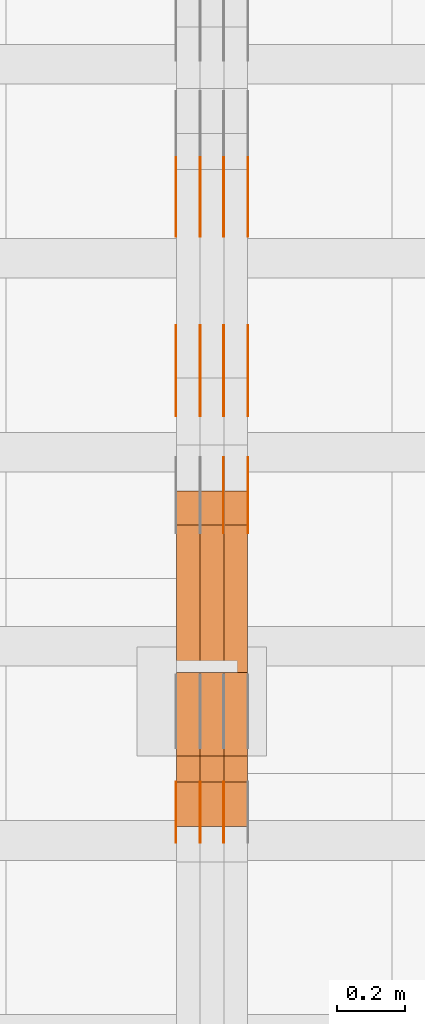
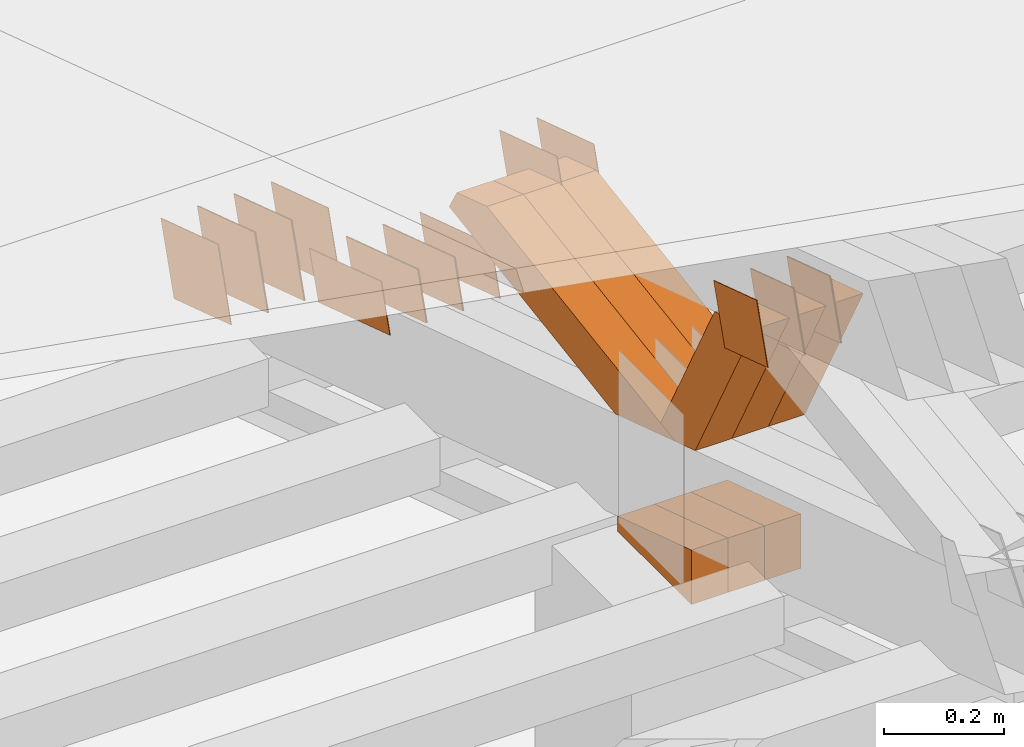
# One storey, part 89 of 385: 28 proxies.
"""IFC2X3 building model written with IfcOpenShell, lengths in millimetres."""

from ifc_helpers import new_model, entity, si_unit, converted_unit, derived_unit, direction, frame, origin, place, context, subcontext, project, spatial, polyline, outline, extrude, source, transform, mapped, material, type_object, type_shapes, element, save


model = new_model("IFC2X3")

# Units and contexts
model_context = context("Model", 3, precision=0.01, world=origin(), true_north=direction((6.12303176911189e-17, 1.0)))
body_context = subcontext(model_context, "Body", "Model", "MODEL_VIEW")
ifc_project = project(units=[si_unit("LENGTHUNIT", "METRE", prefix="MILLI"), si_unit("AREAUNIT", "SQUARE_METRE"), si_unit("VOLUMEUNIT", "CUBIC_METRE"), converted_unit("PLANEANGLEUNIT", "DEGREE", entity("IfcRatioMeasure", 0.0174532925199433), si_unit("PLANEANGLEUNIT", "RADIAN"), dimensions=[0, 0, 0, 0, 0, 0, 0]), si_unit("MASSUNIT", "GRAM", prefix="KILO"), derived_unit("MASSDENSITYUNIT", [(si_unit("MASSUNIT", "GRAM", prefix="KILO"), 1), (si_unit("LENGTHUNIT", "METRE"), -3)]), si_unit("TIMEUNIT", "SECOND"), si_unit("FREQUENCYUNIT", "HERTZ"), si_unit("THERMODYNAMICTEMPERATUREUNIT", "DEGREE_CELSIUS"), derived_unit("THERMALTRANSMITTANCEUNIT", [(si_unit("MASSUNIT", "GRAM", prefix="KILO"), 1), (si_unit("THERMODYNAMICTEMPERATUREUNIT", "KELVIN"), -1), (si_unit("TIMEUNIT", "SECOND"), -3)]), derived_unit("VOLUMETRICFLOWRATEUNIT", [(si_unit("LENGTHUNIT", "METRE"), 3), (si_unit("TIMEUNIT", "SECOND"), -1)]), si_unit("ELECTRICCURRENTUNIT", "AMPERE"), si_unit("ELECTRICVOLTAGEUNIT", "VOLT"), si_unit("POWERUNIT", "WATT"), si_unit("FORCEUNIT", "NEWTON", prefix="KILO"), si_unit("ILLUMINANCEUNIT", "LUX"), si_unit("LUMINOUSFLUXUNIT", "LUMEN"), si_unit("LUMINOUSINTENSITYUNIT", "CANDELA"), derived_unit("USERDEFINED", [(si_unit("MASSUNIT", "GRAM", prefix="KILO"), -1), (si_unit("LENGTHUNIT", "METRE"), -2), (si_unit("TIMEUNIT", "SECOND"), 3), (si_unit("LUMINOUSFLUXUNIT", "LUMEN"), 1)]), derived_unit("LINEARVELOCITYUNIT", [(si_unit("LENGTHUNIT", "METRE"), 1), (si_unit("TIMEUNIT", "SECOND"), -1)]), si_unit("PRESSUREUNIT", "PASCAL"), derived_unit("USERDEFINED", [(si_unit("LENGTHUNIT", "METRE"), -2), (si_unit("MASSUNIT", "GRAM", prefix="KILO"), 1), (si_unit("TIMEUNIT", "SECOND"), -2)])], contexts=[model_context])

# Site, building, storey
site_placement = place(None, origin())
site = spatial("IfcSite", under=ifc_project, at=site_placement, CompositionType="ELEMENT")
building_placement = place(site_placement, origin())
building = spatial("IfcBuilding", under=site, at=building_placement, CompositionType="ELEMENT")
storey_placement = place(building_placement, origin())
storey = spatial("IfcBuildingStorey", under=building, at=storey_placement, Name="Default", CompositionType="ELEMENT", Elevation=0.0)

# Proxies
ifc_material_1 = material(Name="IfcSurfaceStyle #101398")
building_element_proxy_type_1 = type_object("IfcBuildingElementProxyType", PredefinedType="NOTDEFINED", material=ifc_material_1)
shared_shape_1 = source(origin(), body_context, "Body", "SweptSolid", [
    extrude(outline(polyline([(-125.00031378339, -47.9999612158856), (125.000225258022, -47.9999612158856), (124.999811678525, 47.9999612158856), (-124.999723153156, 47.9999612158856), (-125.00031378339, -47.9999612158856)])), frame((125.000225258022, 48.0000091013474, 0.0), z_axis=(0.0, 0.0, 1.0), x_axis=(-1.0, 0.0, 0.0)), (0.0, 0.0, 1.0), 1.3),
])
type_shapes(building_element_proxy_type_1, [shared_shape_1])
proxy_1_placement = place(building_placement, frame((6386.29999999999, 18456.8597683375, 2657.46691321253), z_axis=(-1.0, 0.0, 0.0), x_axis=(0.0, -0.951056516295124, 0.309016994375039)))
element("IfcBuildingElementProxy", 1, at=proxy_1_placement, inside=storey, type_object=building_element_proxy_type_1, material=ifc_material_1, context=body_context, shape_type="MappedRepresentation", body=[
    mapped(shared_shape_1, transform((0.0, 0.0, 0.0), scale=1.0)),
])
ifc_material_2 = material(Name="IfcSurfaceStyle #101341")
building_element_proxy_type_2 = type_object("IfcBuildingElementProxyType", PredefinedType="NOTDEFINED", material=ifc_material_2)
shared_shape_2 = source(origin(), body_context, "Body", "SweptSolid", [
    extrude(outline(polyline([(-125.00031378339, -47.9999612158856), (125.000225258022, -47.9999612158856), (124.999811678525, 47.9999612158856), (-124.999723153156, 47.9999612158856), (-125.00031378339, -47.9999612158856)])), frame((125.000225258022, 48.0000091013474, 0.0), z_axis=(0.0, 0.0, 1.0), x_axis=(-1.0, 0.0, 0.0)), (0.0, 0.0, 1.0), 1.3),
])
type_shapes(building_element_proxy_type_2, [shared_shape_2])
proxy_2_placement = place(building_placement, frame((6315.0, 18456.8597683375, 2657.46691321253), z_axis=(-1.0, 0.0, 0.0), x_axis=(0.0, -0.951056516295124, 0.309016994375039)))
element("IfcBuildingElementProxy", 2, at=proxy_2_placement, inside=storey, type_object=building_element_proxy_type_2, material=ifc_material_2, context=body_context, shape_type="MappedRepresentation", body=[
    mapped(shared_shape_2, transform((0.0, 0.0, 0.0), scale=1.0)),
])
ifc_material_3 = material(Name="IfcSurfaceStyle #101284")
building_element_proxy_type_3 = type_object("IfcBuildingElementProxyType", PredefinedType="NOTDEFINED", material=ifc_material_3)
shared_shape_3 = source(origin(), body_context, "Body", "SweptSolid", [
    extrude(outline(polyline([(-125.00031378339, -47.9999612158856), (125.000225258022, -47.9999612158856), (124.999811678525, 47.9999612158856), (-124.999723153156, 47.9999612158856), (-125.00031378339, -47.9999612158856)])), frame((125.000225258022, 48.0000091013474, 0.0), z_axis=(0.0, 0.0, 1.0), x_axis=(-1.0, 0.0, 0.0)), (0.0, 0.0, 1.0), 1.3),
])
type_shapes(building_element_proxy_type_3, [shared_shape_3])
proxy_3_placement = place(building_placement, frame((6316.29999999999, 18456.8597683375, 2657.46691321253), z_axis=(-1.0, 0.0, 0.0), x_axis=(0.0, -0.951056516295124, 0.309016994375039)))
element("IfcBuildingElementProxy", 3, at=proxy_3_placement, inside=storey, type_object=building_element_proxy_type_3, material=ifc_material_3, context=body_context, shape_type="MappedRepresentation", body=[
    mapped(shared_shape_3, transform((0.0, 0.0, 0.0), scale=1.0)),
])
ifc_material_4 = material(Name="IfcSurfaceStyle #101227")
building_element_proxy_type_4 = type_object("IfcBuildingElementProxyType", PredefinedType="NOTDEFINED", material=ifc_material_4)
shared_shape_4 = source(origin(), body_context, "Body", "SweptSolid", [
    extrude(outline(polyline([(-125.00031378339, -47.9999612158856), (125.000225258022, -47.9999612158856), (124.999811678525, 47.9999612158856), (-124.999723153156, 47.9999612158856), (-125.00031378339, -47.9999612158856)])), frame((125.000225258022, 48.0000091013474, 0.0), z_axis=(0.0, 0.0, 1.0), x_axis=(-1.0, 0.0, 0.0)), (0.0, 0.0, 1.0), 1.29999999999998),
])
type_shapes(building_element_proxy_type_4, [shared_shape_4])
proxy_4_placement = place(building_placement, frame((6245.0, 18456.8597683375, 2657.46691321253), z_axis=(-1.0, 0.0, 0.0), x_axis=(0.0, -0.951056516295124, 0.309016994375039)))
element("IfcBuildingElementProxy", 4, at=proxy_4_placement, inside=storey, type_object=building_element_proxy_type_4, material=ifc_material_4, context=body_context, shape_type="MappedRepresentation", body=[
    mapped(shared_shape_4, transform((0.0, 0.0, 0.0), scale=1.0)),
])
ifc_material_5 = material(Name="IfcSurfaceStyle #101170")
building_element_proxy_type_5 = type_object("IfcBuildingElementProxyType", PredefinedType="NOTDEFINED", material=ifc_material_5)
shared_shape_5 = source(origin(), body_context, "Body", "SweptSolid", [
    extrude(outline(polyline([(-125.00031378339, -47.9999612158856), (125.000225258022, -47.9999612158856), (124.999811678525, 47.9999612158856), (-124.999723153156, 47.9999612158856), (-125.00031378339, -47.9999612158856)])), frame((125.000225258022, 48.0000091013474, 0.0), z_axis=(0.0, 0.0, 1.0), x_axis=(-1.0, 0.0, 0.0)), (0.0, 0.0, 1.0), 1.29999999999998),
])
type_shapes(building_element_proxy_type_5, [shared_shape_5])
proxy_5_placement = place(building_placement, frame((6246.29999999999, 18456.8597683375, 2657.46691321253), z_axis=(-1.0, 0.0, 0.0), x_axis=(0.0, -0.951056516295124, 0.309016994375039)))
element("IfcBuildingElementProxy", 5, at=proxy_5_placement, inside=storey, type_object=building_element_proxy_type_5, material=ifc_material_5, context=body_context, shape_type="MappedRepresentation", body=[
    mapped(shared_shape_5, transform((0.0, 0.0, 0.0), scale=1.0)),
])
ifc_material_6 = material(Name="IfcSurfaceStyle #101113")
building_element_proxy_type_6 = type_object("IfcBuildingElementProxyType", PredefinedType="NOTDEFINED", material=ifc_material_6)
shared_shape_6 = source(origin(), body_context, "Body", "SweptSolid", [
    extrude(outline(polyline([(-125.00031378339, -47.9999612158856), (125.000225258022, -47.9999612158856), (124.999811678525, 47.9999612158856), (-124.999723153156, 47.9999612158856), (-125.00031378339, -47.9999612158856)])), frame((125.000225258022, 48.0000091013474, 0.0), z_axis=(0.0, 0.0, 1.0), x_axis=(-1.0, 0.0, 0.0)), (0.0, 0.0, 1.0), 1.29999999999998),
])
type_shapes(building_element_proxy_type_6, [shared_shape_6])
proxy_6_placement = place(building_placement, frame((6175.0, 18456.8597683375, 2657.46691321253), z_axis=(-1.0, 0.0, 0.0), x_axis=(0.0, -0.951056516295124, 0.309016994375039)))
element("IfcBuildingElementProxy", 6, at=proxy_6_placement, inside=storey, type_object=building_element_proxy_type_6, material=ifc_material_6, context=body_context, shape_type="MappedRepresentation", body=[
    mapped(shared_shape_6, transform((0.0, 0.0, 0.0), scale=1.0)),
])
ifc_material_7 = material(Name="IfcSurfaceStyle #99688")
building_element_proxy_type_7 = type_object("IfcBuildingElementProxyType", PredefinedType="NOTDEFINED", material=ifc_material_7)
shared_shape_7 = source(origin(), body_context, "Body", "SweptSolid", [
    extrude(outline(polyline([(-99.999796294464, -72.0000050220467), (99.9998768370438, -72.0000050220467), (100.000260677528, 72.0000050220467), (-100.000341220108, 72.0000050220467), (-99.999796294464, -72.0000050220467)])), frame((100.000260677528, 72.0000050220467, 0.0), z_axis=(0.0, 0.0, 1.0), x_axis=(-1.0, 0.0, 0.0)), (0.0, 0.0, 1.0), 1.3),
])
type_shapes(building_element_proxy_type_7, [shared_shape_7])
proxy_7_placement = place(building_placement, frame((6386.29999999999, 18936.3876569477, 2373.90613192527), z_axis=(-1.0, 0.0, 0.0), x_axis=(0.0, -0.951056516295124, 0.309016994375039)))
element("IfcBuildingElementProxy", 7, at=proxy_7_placement, inside=storey, type_object=building_element_proxy_type_7, material=ifc_material_7, context=body_context, shape_type="MappedRepresentation", body=[
    mapped(shared_shape_7, transform((0.0, 0.0, 0.0), scale=1.0)),
])
ifc_material_8 = material(Name="IfcSurfaceStyle #99631")
building_element_proxy_type_8 = type_object("IfcBuildingElementProxyType", PredefinedType="NOTDEFINED", material=ifc_material_8)
shared_shape_8 = source(origin(), body_context, "Body", "SweptSolid", [
    extrude(outline(polyline([(-99.999796294464, -72.0000050220467), (99.9998768370438, -72.0000050220467), (100.000260677528, 72.0000050220467), (-100.000341220108, 72.0000050220467), (-99.999796294464, -72.0000050220467)])), frame((100.000260677528, 72.0000050220467, 0.0), z_axis=(0.0, 0.0, 1.0), x_axis=(-1.0, 0.0, 0.0)), (0.0, 0.0, 1.0), 1.3),
])
type_shapes(building_element_proxy_type_8, [shared_shape_8])
proxy_8_placement = place(building_placement, frame((6315.0, 18936.3876569477, 2373.90613192527), z_axis=(-1.0, 0.0, 0.0), x_axis=(0.0, -0.951056516295124, 0.309016994375039)))
element("IfcBuildingElementProxy", 8, at=proxy_8_placement, inside=storey, type_object=building_element_proxy_type_8, material=ifc_material_8, context=body_context, shape_type="MappedRepresentation", body=[
    mapped(shared_shape_8, transform((0.0, 0.0, 0.0), scale=1.0)),
])
ifc_material_9 = material(Name="IfcSurfaceStyle #99574")
building_element_proxy_type_9 = type_object("IfcBuildingElementProxyType", PredefinedType="NOTDEFINED", material=ifc_material_9)
shared_shape_9 = source(origin(), body_context, "Body", "SweptSolid", [
    extrude(outline(polyline([(-99.999796294464, -72.0000050220467), (99.9998768370438, -72.0000050220467), (100.000260677528, 72.0000050220467), (-100.000341220108, 72.0000050220467), (-99.999796294464, -72.0000050220467)])), frame((100.000260677528, 72.0000050220467, 0.0), z_axis=(0.0, 0.0, 1.0), x_axis=(-1.0, 0.0, 0.0)), (0.0, 0.0, 1.0), 1.3),
])
type_shapes(building_element_proxy_type_9, [shared_shape_9])
proxy_9_placement = place(building_placement, frame((6316.29999999999, 18936.3876569477, 2373.90613192527), z_axis=(-1.0, 0.0, 0.0), x_axis=(0.0, -0.951056516295124, 0.309016994375039)))
element("IfcBuildingElementProxy", 9, at=proxy_9_placement, inside=storey, type_object=building_element_proxy_type_9, material=ifc_material_9, context=body_context, shape_type="MappedRepresentation", body=[
    mapped(shared_shape_9, transform((0.0, 0.0, 0.0), scale=1.0)),
])
ifc_material_10 = material(Name="IfcSurfaceStyle #99517")
building_element_proxy_type_10 = type_object("IfcBuildingElementProxyType", PredefinedType="NOTDEFINED", material=ifc_material_10)
shared_shape_10 = source(origin(), body_context, "Body", "SweptSolid", [
    extrude(outline(polyline([(-99.999796294464, -72.0000050220467), (99.9998768370438, -72.0000050220467), (100.000260677528, 72.0000050220467), (-100.000341220108, 72.0000050220467), (-99.999796294464, -72.0000050220467)])), frame((100.000260677528, 72.0000050220467, 0.0), z_axis=(0.0, 0.0, 1.0), x_axis=(-1.0, 0.0, 0.0)), (0.0, 0.0, 1.0), 1.29999999999998),
])
type_shapes(building_element_proxy_type_10, [shared_shape_10])
proxy_10_placement = place(building_placement, frame((6245.0, 18936.3876569477, 2373.90613192527), z_axis=(-1.0, 0.0, 0.0), x_axis=(0.0, -0.951056516295124, 0.309016994375039)))
element("IfcBuildingElementProxy", 10, at=proxy_10_placement, inside=storey, type_object=building_element_proxy_type_10, material=ifc_material_10, context=body_context, shape_type="MappedRepresentation", body=[
    mapped(shared_shape_10, transform((0.0, 0.0, 0.0), scale=1.0)),
])
ifc_material_11 = material(Name="IfcSurfaceStyle #99460")
building_element_proxy_type_11 = type_object("IfcBuildingElementProxyType", PredefinedType="NOTDEFINED", material=ifc_material_11)
shared_shape_11 = source(origin(), body_context, "Body", "SweptSolid", [
    extrude(outline(polyline([(-99.999796294464, -72.0000050220467), (99.9998768370438, -72.0000050220467), (100.000260677528, 72.0000050220467), (-100.000341220108, 72.0000050220467), (-99.999796294464, -72.0000050220467)])), frame((100.000260677528, 72.0000050220467, 0.0), z_axis=(0.0, 0.0, 1.0), x_axis=(-1.0, 0.0, 0.0)), (0.0, 0.0, 1.0), 1.29999999999998),
])
type_shapes(building_element_proxy_type_11, [shared_shape_11])
proxy_11_placement = place(building_placement, frame((6246.29999999999, 18936.3876569477, 2373.90613192527), z_axis=(-1.0, 0.0, 0.0), x_axis=(0.0, -0.951056516295124, 0.309016994375039)))
element("IfcBuildingElementProxy", 11, at=proxy_11_placement, inside=storey, type_object=building_element_proxy_type_11, material=ifc_material_11, context=body_context, shape_type="MappedRepresentation", body=[
    mapped(shared_shape_11, transform((0.0, 0.0, 0.0), scale=1.0)),
])
ifc_material_12 = material(Name="IfcSurfaceStyle #99403")
building_element_proxy_type_12 = type_object("IfcBuildingElementProxyType", PredefinedType="NOTDEFINED", material=ifc_material_12)
shared_shape_12 = source(origin(), body_context, "Body", "SweptSolid", [
    extrude(outline(polyline([(-99.999796294464, -72.0000050220467), (99.9998768370438, -72.0000050220467), (100.000260677528, 72.0000050220467), (-100.000341220108, 72.0000050220467), (-99.999796294464, -72.0000050220467)])), frame((100.000260677528, 72.0000050220467, 0.0), z_axis=(0.0, 0.0, 1.0), x_axis=(-1.0, 0.0, 0.0)), (0.0, 0.0, 1.0), 1.29999999999999),
])
type_shapes(building_element_proxy_type_12, [shared_shape_12])
proxy_12_placement = place(building_placement, frame((6175.0, 18936.3876569477, 2373.90613192527), z_axis=(-1.0, 0.0, 0.0), x_axis=(0.0, -0.951056516295124, 0.309016994375039)))
element("IfcBuildingElementProxy", 12, at=proxy_12_placement, inside=storey, type_object=building_element_proxy_type_12, material=ifc_material_12, context=body_context, shape_type="MappedRepresentation", body=[
    mapped(shared_shape_12, transform((0.0, 0.0, 0.0), scale=1.0)),
])
ifc_material_13 = material(Name="IfcSurfaceStyle #95869")
building_element_proxy_type_13 = type_object("IfcBuildingElementProxyType", PredefinedType="NOTDEFINED", material=ifc_material_13)
shared_shape_13 = source(origin(), body_context, "Body", "SweptSolid", [
    extrude(outline(polyline([(-74.9998605591058, -59.9999264677524), (74.999875428623, -59.9999264677524), (74.9998605591068, 59.9999264677524), (-74.9998754286239, 59.9999264677524), (-74.9998605591058, -59.9999264677524)])), frame((75.0002460484325, 60.0000016373508, 0.0), z_axis=(0.0, 0.0, 1.0), x_axis=(-1.0, 0.0, 0.0)), (0.0, 0.0, 1.0), 1.3),
])
type_shapes(building_element_proxy_type_13, [shared_shape_13])
proxy_13_placement = place(building_placement, frame((6315.0, 17107.0599369346, 3383.82825001787), z_axis=(-1.0, 0.0, 0.0), x_axis=(0.0, -0.951056516295154, 0.309016994374948)))
element("IfcBuildingElementProxy", 13, at=proxy_13_placement, inside=storey, type_object=building_element_proxy_type_13, material=ifc_material_13, context=body_context, shape_type="MappedRepresentation", body=[
    mapped(shared_shape_13, transform((0.0, 0.0, 0.0), scale=1.0)),
])
ifc_material_14 = material(Name="IfcSurfaceStyle #95812")
building_element_proxy_type_14 = type_object("IfcBuildingElementProxyType", PredefinedType="NOTDEFINED", material=ifc_material_14)
shared_shape_14 = source(origin(), body_context, "Body", "SweptSolid", [
    extrude(outline(polyline([(-74.9998605591058, -59.9999264677524), (74.999875428623, -59.9999264677524), (74.9998605591068, 59.9999264677524), (-74.9998754286239, 59.9999264677524), (-74.9998605591058, -59.9999264677524)])), frame((75.0002460484325, 60.0000016373508, 0.0), z_axis=(0.0, 0.0, 1.0), x_axis=(-1.0, 0.0, 0.0)), (0.0, 0.0, 1.0), 1.3),
])
type_shapes(building_element_proxy_type_14, [shared_shape_14])
proxy_14_placement = place(building_placement, frame((6316.29999999999, 17107.0599369346, 3383.82825001787), z_axis=(-1.0, 0.0, 0.0), x_axis=(0.0, -0.951056516295154, 0.309016994374948)))
element("IfcBuildingElementProxy", 14, at=proxy_14_placement, inside=storey, type_object=building_element_proxy_type_14, material=ifc_material_14, context=body_context, shape_type="MappedRepresentation", body=[
    mapped(shared_shape_14, transform((0.0, 0.0, 0.0), scale=1.0)),
])
ifc_material_15 = material(Name="IfcSurfaceStyle #95755")
building_element_proxy_type_15 = type_object("IfcBuildingElementProxyType", PredefinedType="NOTDEFINED", material=ifc_material_15)
shared_shape_15 = source(origin(), body_context, "Body", "SweptSolid", [
    extrude(outline(polyline([(-74.9998605591058, -59.9999264677524), (74.999875428623, -59.9999264677524), (74.9998605591068, 59.9999264677524), (-74.9998754286239, 59.9999264677524), (-74.9998605591058, -59.9999264677524)])), frame((75.0002460484325, 60.0000016373508, 0.0), z_axis=(0.0, 0.0, 1.0), x_axis=(-1.0, 0.0, 0.0)), (0.0, 0.0, 1.0), 1.29999999999999),
])
type_shapes(building_element_proxy_type_15, [shared_shape_15])
proxy_15_placement = place(building_placement, frame((6245.0, 17107.0599369346, 3383.82825001787), z_axis=(-1.0, 0.0, 0.0), x_axis=(0.0, -0.951056516295154, 0.309016994374948)))
element("IfcBuildingElementProxy", 15, at=proxy_15_placement, inside=storey, type_object=building_element_proxy_type_15, material=ifc_material_15, context=body_context, shape_type="MappedRepresentation", body=[
    mapped(shared_shape_15, transform((0.0, 0.0, 0.0), scale=1.0)),
])
ifc_material_16 = material(Name="IfcSurfaceStyle #95698")
building_element_proxy_type_16 = type_object("IfcBuildingElementProxyType", PredefinedType="NOTDEFINED", material=ifc_material_16)
shared_shape_16 = source(origin(), body_context, "Body", "SweptSolid", [
    extrude(outline(polyline([(-74.9998605591058, -59.9999264677524), (74.999875428623, -59.9999264677524), (74.9998605591068, 59.9999264677524), (-74.9998754286239, 59.9999264677524), (-74.9998605591058, -59.9999264677524)])), frame((75.0002460484325, 60.0000016373508, 0.0), z_axis=(0.0, 0.0, 1.0), x_axis=(-1.0, 0.0, 0.0)), (0.0, 0.0, 1.0), 1.29999999999999),
])
type_shapes(building_element_proxy_type_16, [shared_shape_16])
proxy_16_placement = place(building_placement, frame((6246.29999999999, 17107.0599369346, 3383.82825001787), z_axis=(-1.0, 0.0, 0.0), x_axis=(0.0, -0.951056516295154, 0.309016994374948)))
element("IfcBuildingElementProxy", 16, at=proxy_16_placement, inside=storey, type_object=building_element_proxy_type_16, material=ifc_material_16, context=body_context, shape_type="MappedRepresentation", body=[
    mapped(shared_shape_16, transform((0.0, 0.0, 0.0), scale=1.0)),
])
ifc_material_17 = material(Name="IfcSurfaceStyle #95641")
building_element_proxy_type_17 = type_object("IfcBuildingElementProxyType", PredefinedType="NOTDEFINED", material=ifc_material_17)
shared_shape_17 = source(origin(), body_context, "Body", "SweptSolid", [
    extrude(outline(polyline([(-74.9998605591058, -59.9999264677524), (74.999875428623, -59.9999264677524), (74.9998605591068, 59.9999264677524), (-74.9998754286239, 59.9999264677524), (-74.9998605591058, -59.9999264677524)])), frame((75.0002460484325, 60.0000016373508, 0.0), z_axis=(0.0, 0.0, 1.0), x_axis=(-1.0, 0.0, 0.0)), (0.0, 0.0, 1.0), 1.29999999999999),
])
type_shapes(building_element_proxy_type_17, [shared_shape_17])
proxy_17_placement = place(building_placement, frame((6175.0, 17107.0599369346, 3383.82825001787), z_axis=(-1.0, 0.0, 0.0), x_axis=(0.0, -0.951056516295154, 0.309016994374948)))
element("IfcBuildingElementProxy", 17, at=proxy_17_placement, inside=storey, type_object=building_element_proxy_type_17, material=ifc_material_17, context=body_context, shape_type="MappedRepresentation", body=[
    mapped(shared_shape_17, transform((0.0, 0.0, 0.0), scale=1.0)),
])
ifc_material_18 = material(Name="IfcSurfaceStyle #95242")
building_element_proxy_type_18 = type_object("IfcBuildingElementProxyType", PredefinedType="NOTDEFINED", material=ifc_material_18)
shared_shape_18 = source(origin(), body_context, "Body", "SweptSolid", [
    extrude(outline(polyline([(-99.9999427841299, -54.0000599375792), (99.9996549037756, -54.0000599375792), (100.000407167194, 54.0000599375792), (-100.00011928684, 54.0000599375792), (-99.9999427841299, -54.0000599375792)])), frame((100.000407167194, 54.0000599375792, 0.0), z_axis=(0.0, 0.0, 1.0), x_axis=(-1.0, 0.0, 0.0)), (0.0, 0.0, 1.0), 1.3),
])
type_shapes(building_element_proxy_type_18, [shared_shape_18])
proxy_18_placement = place(building_placement, frame((6386.29999999999, 18065.0682492591, 3072.55239547302), z_axis=(-1.0, 0.0, 0.0), x_axis=(0.0, -0.951056516295154, 0.309016994374948)))
element("IfcBuildingElementProxy", 18, at=proxy_18_placement, inside=storey, type_object=building_element_proxy_type_18, material=ifc_material_18, context=body_context, shape_type="MappedRepresentation", body=[
    mapped(shared_shape_18, transform((0.0, 0.0, 0.0), scale=1.0)),
])
ifc_material_19 = material(Name="IfcSurfaceStyle #95185")
building_element_proxy_type_19 = type_object("IfcBuildingElementProxyType", PredefinedType="NOTDEFINED", material=ifc_material_19)
shared_shape_19 = source(origin(), body_context, "Body", "SweptSolid", [
    extrude(outline(polyline([(-99.9999427841299, -54.0000599375792), (99.9996549037756, -54.0000599375792), (100.000407167194, 54.0000599375792), (-100.00011928684, 54.0000599375792), (-99.9999427841299, -54.0000599375792)])), frame((100.000407167194, 54.0000599375792, 0.0), z_axis=(0.0, 0.0, 1.0), x_axis=(-1.0, 0.0, 0.0)), (0.0, 0.0, 1.0), 1.3),
])
type_shapes(building_element_proxy_type_19, [shared_shape_19])
proxy_19_placement = place(building_placement, frame((6315.0, 18065.0682492591, 3072.55239547302), z_axis=(-1.0, 0.0, 0.0), x_axis=(0.0, -0.951056516295154, 0.309016994374948)))
element("IfcBuildingElementProxy", 19, at=proxy_19_placement, inside=storey, type_object=building_element_proxy_type_19, material=ifc_material_19, context=body_context, shape_type="MappedRepresentation", body=[
    mapped(shared_shape_19, transform((0.0, 0.0, 0.0), scale=1.0)),
])
ifc_material_20 = material(Name="IfcSurfaceStyle #87637")
building_element_proxy_type_20 = type_object("IfcBuildingElementProxyType", Name="T1-E1 87635", PredefinedType="NOTDEFINED", material=ifc_material_20)
shared_shape_20 = source(origin(), body_context, "Body", "SweptSolid", [
    extrude(outline(polyline([(4.4675903320374, -122.500000000001), (35.3350219726624, -122.500000000001), (35.3350219726501, 122.500000000001), (-75.1376342773499, 122.500000000001), (4.4675903320374, -122.500000000001)])), frame((35.3350219726624, 122.50000005215, 0.0), z_axis=(0.0, 0.0, 1.0), x_axis=(-1.0, 0.0, 0.0)), (0.0, 0.0, 1.0), 70.0),
])
type_shapes(building_element_proxy_type_20, [shared_shape_20])
proxy_20_placement = place(building_placement, frame((6385.0, 17220.0, 2794.30932617186), z_axis=(-1.0, 0.0, 0.0), x_axis=(0.0, 0.0, 1.0)))
element("IfcBuildingElementProxy", 20, at=proxy_20_placement, inside=storey, type_object=building_element_proxy_type_20, material=ifc_material_20, Name="T1-E1", context=body_context, shape_type="MappedRepresentation", body=[
    mapped(shared_shape_20, transform((0.0, 0.0, 0.0), scale=1.0)),
])
ifc_material_21 = material(Name="IfcSurfaceStyle #87580")
building_element_proxy_type_21 = type_object("IfcBuildingElementProxyType", Name="T1-E1 87578", PredefinedType="NOTDEFINED", material=ifc_material_21)
shared_shape_21 = source(origin(), body_context, "Body", "SweptSolid", [
    extrude(outline(polyline([(4.4675903320374, -122.500000000001), (35.3350219726624, -122.500000000001), (35.3350219726501, 122.500000000001), (-75.1376342773499, 122.500000000001), (4.4675903320374, -122.500000000001)])), frame((35.3350219726624, 122.50000005215, 0.0), z_axis=(0.0, 0.0, 1.0), x_axis=(-1.0, 0.0, 0.0)), (0.0, 0.0, 1.0), 70.0),
])
type_shapes(building_element_proxy_type_21, [shared_shape_21])
proxy_21_placement = place(building_placement, frame((6315.0, 17220.0, 2794.30932617186), z_axis=(-1.0, 0.0, 0.0), x_axis=(0.0, 0.0, 1.0)))
element("IfcBuildingElementProxy", 21, at=proxy_21_placement, inside=storey, type_object=building_element_proxy_type_21, material=ifc_material_21, Name="T1-E1", context=body_context, shape_type="MappedRepresentation", body=[
    mapped(shared_shape_21, transform((0.0, 0.0, 0.0), scale=1.0)),
])
ifc_material_22 = material(Name="IfcSurfaceStyle #87523")
building_element_proxy_type_22 = type_object("IfcBuildingElementProxyType", Name="T1-E1 87521", PredefinedType="NOTDEFINED", material=ifc_material_22)
shared_shape_22 = source(origin(), body_context, "Body", "SweptSolid", [
    extrude(outline(polyline([(4.4675903320374, -122.500000000001), (35.3350219726624, -122.500000000001), (35.3350219726501, 122.500000000001), (-75.1376342773499, 122.500000000001), (4.4675903320374, -122.500000000001)])), frame((35.3350219726624, 122.50000005215, 0.0), z_axis=(0.0, 0.0, 1.0), x_axis=(-1.0, 0.0, 0.0)), (0.0, 0.0, 1.0), 70.0),
])
type_shapes(building_element_proxy_type_22, [shared_shape_22])
proxy_22_placement = place(building_placement, frame((6245.0, 17220.0, 2794.30932617186), z_axis=(-1.0, 0.0, 0.0), x_axis=(0.0, 0.0, 1.0)))
element("IfcBuildingElementProxy", 22, at=proxy_22_placement, inside=storey, type_object=building_element_proxy_type_22, material=ifc_material_22, Name="T1-E1", context=body_context, shape_type="MappedRepresentation", body=[
    mapped(shared_shape_22, transform((0.0, 0.0, 0.0), scale=1.0)),
])
ifc_material_23 = material(Name="IfcSurfaceStyle #85882")
building_element_proxy_type_23 = type_object("IfcBuildingElementProxyType", Name="T1-W39 85880", PredefinedType="NOTDEFINED", material=ifc_material_23)
shared_shape_23 = source(origin(), body_context, "Body", "SweptSolid", [
    extrude(outline(polyline([(-191.519946663886, -47.499928106579), (188.32936223763, -47.499928106579), (171.597440144109, 0.000249483340993841), (122.102882529753, 47.4998033649085), (-290.509738247605, 47.4998033649085), (-191.519946663886, -47.499928106579)])), frame((188.329593252001, 47.499957247623, 0.0), z_axis=(0.0, 0.0, 1.0), x_axis=(-1.0, 0.0, 0.0)), (0.0, 0.0, 1.0), 70.0),
])
type_shapes(building_element_proxy_type_23, [shared_shape_23])
proxy_23_placement = place(building_placement, frame((6385.0, 17238.5876916597, 3055.56121424762), z_axis=(-1.0, 0.0, 0.0), x_axis=(0.0, -0.472216932390777, 0.881482370080902)))
element("IfcBuildingElementProxy", 23, at=proxy_23_placement, inside=storey, type_object=building_element_proxy_type_23, material=ifc_material_23, Name="T1-W39", context=body_context, shape_type="MappedRepresentation", body=[
    mapped(shared_shape_23, transform((0.0, 0.0, 0.0), scale=1.0)),
])
ifc_material_24 = material(Name="IfcSurfaceStyle #85816")
building_element_proxy_type_24 = type_object("IfcBuildingElementProxyType", Name="T1-W39 85814", PredefinedType="NOTDEFINED", material=ifc_material_24)
shared_shape_24 = source(origin(), body_context, "Body", "SweptSolid", [
    extrude(outline(polyline([(-191.519946663886, -47.499928106579), (188.32936223763, -47.499928106579), (171.597440144109, 0.000249483340993841), (122.102882529753, 47.4998033649085), (-290.509738247605, 47.4998033649085), (-191.519946663886, -47.499928106579)])), frame((188.329593252001, 47.499957247623, 0.0), z_axis=(0.0, 0.0, 1.0), x_axis=(-1.0, 0.0, 0.0)), (0.0, 0.0, 1.0), 70.0),
])
type_shapes(building_element_proxy_type_24, [shared_shape_24])
proxy_24_placement = place(building_placement, frame((6315.0, 17238.5876916597, 3055.56121424762), z_axis=(-1.0, 0.0, 0.0), x_axis=(0.0, -0.472216932390777, 0.881482370080902)))
element("IfcBuildingElementProxy", 24, at=proxy_24_placement, inside=storey, type_object=building_element_proxy_type_24, material=ifc_material_24, Name="T1-W39", context=body_context, shape_type="MappedRepresentation", body=[
    mapped(shared_shape_24, transform((0.0, 0.0, 0.0), scale=1.0)),
])
ifc_material_25 = material(Name="IfcSurfaceStyle #85750")
building_element_proxy_type_25 = type_object("IfcBuildingElementProxyType", Name="T1-W39 85748", PredefinedType="NOTDEFINED", material=ifc_material_25)
shared_shape_25 = source(origin(), body_context, "Body", "SweptSolid", [
    extrude(outline(polyline([(-191.519946663886, -47.499928106579), (188.32936223763, -47.499928106579), (171.597440144109, 0.000249483340993841), (122.102882529753, 47.4998033649085), (-290.509738247605, 47.4998033649085), (-191.519946663886, -47.499928106579)])), frame((188.329593252001, 47.499957247623, 0.0), z_axis=(0.0, 0.0, 1.0), x_axis=(-1.0, 0.0, 0.0)), (0.0, 0.0, 1.0), 70.0),
])
type_shapes(building_element_proxy_type_25, [shared_shape_25])
proxy_25_placement = place(building_placement, frame((6245.0, 17238.5876916597, 3055.56121424762), z_axis=(-1.0, 0.0, 0.0), x_axis=(0.0, -0.472216932390777, 0.881482370080902)))
element("IfcBuildingElementProxy", 25, at=proxy_25_placement, inside=storey, type_object=building_element_proxy_type_25, material=ifc_material_25, Name="T1-W39", context=body_context, shape_type="MappedRepresentation", body=[
    mapped(shared_shape_25, transform((0.0, 0.0, 0.0), scale=1.0)),
])
ifc_material_26 = material(Name="IfcSurfaceStyle #85486")
building_element_proxy_type_26 = type_object("IfcBuildingElementProxyType", Name="T1-W10 85484", PredefinedType="NOTDEFINED", material=ifc_material_26)
shared_shape_26 = source(origin(), body_context, "Body", "SweptSolid", [
    extrude(outline(polyline([(-459.546036710757, -47.5000436364511), (174.689450869018, -47.5000436364511), (268.831081103959, 0.00011114562912502), (287.286350706789, 47.4999880636365), (-271.260845969009, 47.4999880636366), (-459.546036710757, -47.5000436364511)])), frame((287.286768781132, 47.5001637448091, 0.0), z_axis=(0.0, 0.0, 1.0), x_axis=(-1.0, 0.0, 0.0)), (0.0, 0.0, 1.0), 70.0),
])
type_shapes(building_element_proxy_type_26, [shared_shape_26])
proxy_26_placement = place(building_placement, frame((6385.0, 18025.1410649788, 3112.76453857986), z_axis=(-1.0, 0.0, 0.0), x_axis=(0.0, -0.988299196256916, -0.152527698068035)))
element("IfcBuildingElementProxy", 26, at=proxy_26_placement, inside=storey, type_object=building_element_proxy_type_26, material=ifc_material_26, Name="T1-W10", context=body_context, shape_type="MappedRepresentation", body=[
    mapped(shared_shape_26, transform((0.0, 0.0, 0.0), scale=1.0)),
])
ifc_material_27 = material(Name="IfcSurfaceStyle #85420")
building_element_proxy_type_27 = type_object("IfcBuildingElementProxyType", Name="T1-W10 85418", PredefinedType="NOTDEFINED", material=ifc_material_27)
shared_shape_27 = source(origin(), body_context, "Body", "SweptSolid", [
    extrude(outline(polyline([(-459.546036710757, -47.5000436364511), (174.689450869018, -47.5000436364511), (268.831081103959, 0.00011114562912502), (287.286350706789, 47.4999880636365), (-271.260845969009, 47.4999880636366), (-459.546036710757, -47.5000436364511)])), frame((287.286768781132, 47.5001637448091, 0.0), z_axis=(0.0, 0.0, 1.0), x_axis=(-1.0, 0.0, 0.0)), (0.0, 0.0, 1.0), 70.0),
])
type_shapes(building_element_proxy_type_27, [shared_shape_27])
proxy_27_placement = place(building_placement, frame((6315.0, 18025.1410649788, 3112.76453857986), z_axis=(-1.0, 0.0, 0.0), x_axis=(0.0, -0.988299196256916, -0.152527698068035)))
element("IfcBuildingElementProxy", 27, at=proxy_27_placement, inside=storey, type_object=building_element_proxy_type_27, material=ifc_material_27, Name="T1-W10", context=body_context, shape_type="MappedRepresentation", body=[
    mapped(shared_shape_27, transform((0.0, 0.0, 0.0), scale=1.0)),
])
ifc_material_28 = material(Name="IfcSurfaceStyle #85354")
building_element_proxy_type_28 = type_object("IfcBuildingElementProxyType", Name="T1-W10 85352", PredefinedType="NOTDEFINED", material=ifc_material_28)
shared_shape_28 = source(origin(), body_context, "Body", "SweptSolid", [
    extrude(outline(polyline([(-459.546036710757, -47.5000436364511), (174.689450869018, -47.5000436364511), (268.831081103959, 0.00011114562912502), (287.286350706789, 47.4999880636365), (-271.260845969009, 47.4999880636366), (-459.546036710757, -47.5000436364511)])), frame((287.286768781132, 47.5001637448091, 0.0), z_axis=(0.0, 0.0, 1.0), x_axis=(-1.0, 0.0, 0.0)), (0.0, 0.0, 1.0), 70.0),
])
type_shapes(building_element_proxy_type_28, [shared_shape_28])
proxy_28_placement = place(building_placement, frame((6245.0, 18025.1410649788, 3112.76453857986), z_axis=(-1.0, 0.0, 0.0), x_axis=(0.0, -0.988299196256916, -0.152527698068035)))
element("IfcBuildingElementProxy", 28, at=proxy_28_placement, inside=storey, type_object=building_element_proxy_type_28, material=ifc_material_28, Name="T1-W10", context=body_context, shape_type="MappedRepresentation", body=[
    mapped(shared_shape_28, transform((0.0, 0.0, 0.0), scale=1.0)),
])

save(model, "model.ifc")
